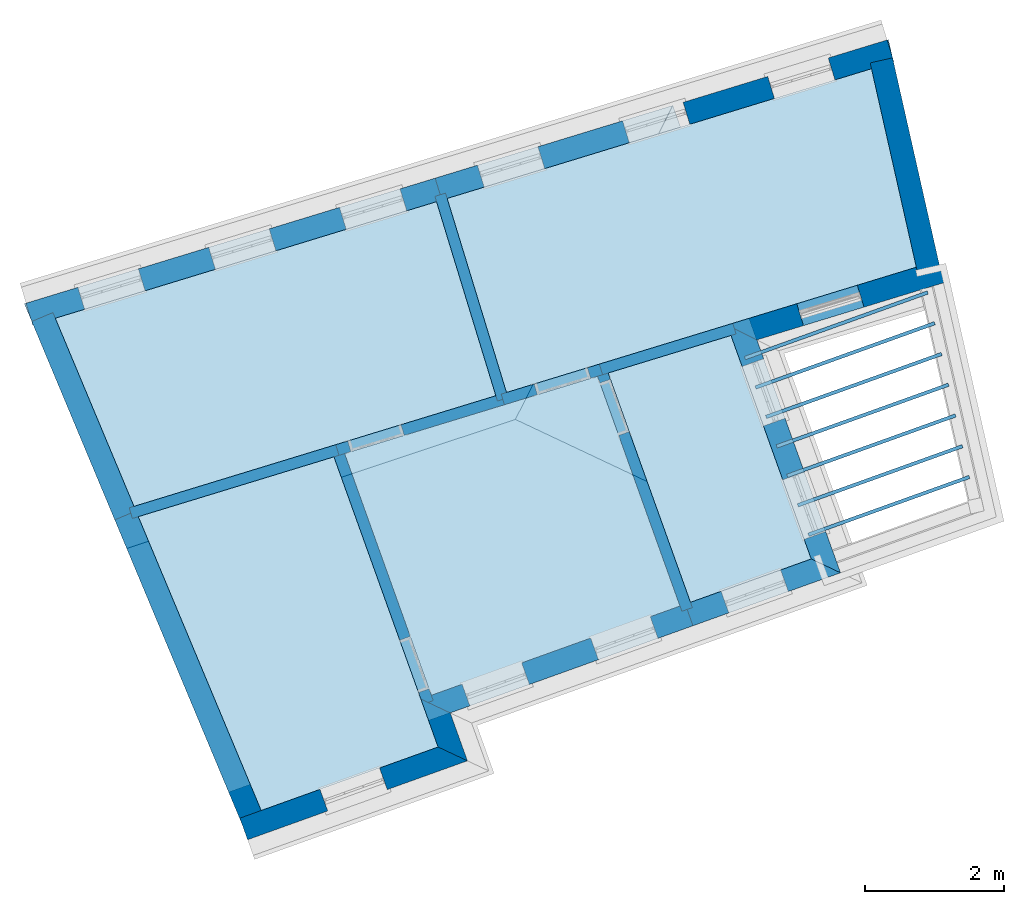
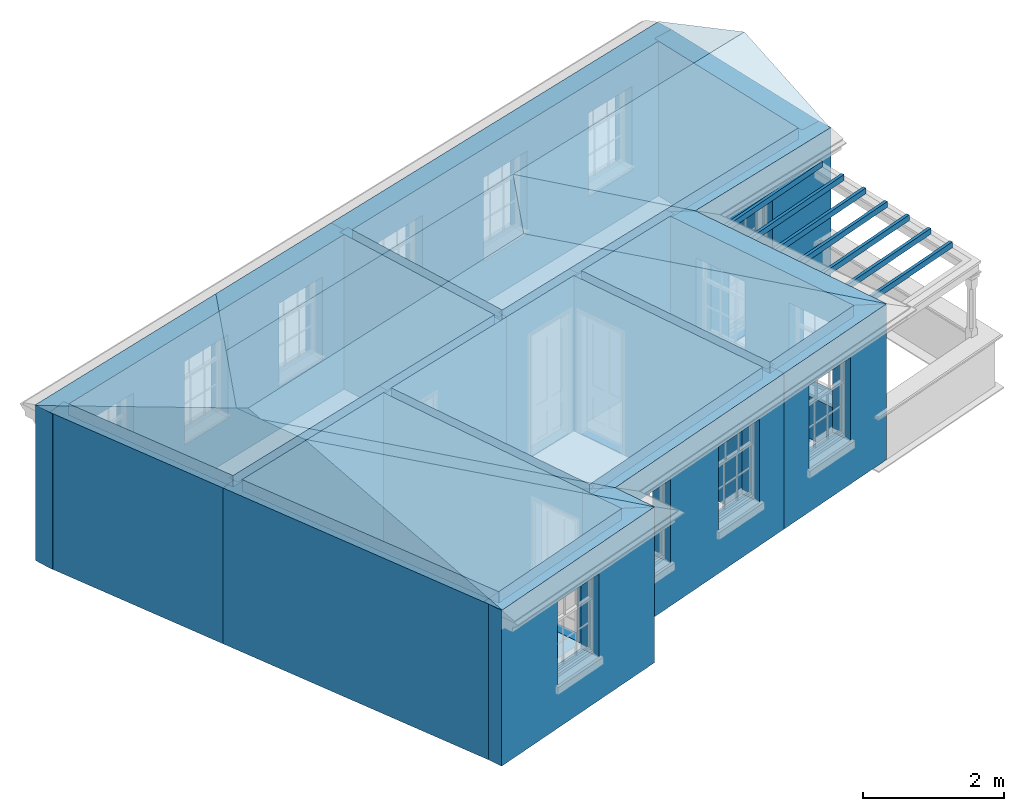
# One storey, part 1 of 10: 18 walls, 16 slabs, 3 roofs, 17 openings.
"""IFC2X3 building model written with IfcOpenShell, lengths in metres."""

import ifcopenshell
import ifcopenshell.guid

model = None  # the IFC model being written
_history = None  # IfcOwnerHistory: only IFC2X3 demands one
_inside = {}  # id of a spatial element -> (the spatial element, [elements in it])
_under = {}  # id of a project, library or spatial element -> (it, [spatial elements below it])
_declared = {}  # id of a project -> (the project, [libraries it declares])
_typed = {}  # id of a type object -> (the type object, [elements of that type])
_made_of = {}  # id of a material, layer set ... -> (it, [elements and type objects made of it])


def new_model(schema):
    """Start an empty IFC model of exactly this schema.

    Asked for "IFC4X3", IfcOpenShell would pick the latest addendum, in which some entities
    have other attributes; the version numbers below select the first issue.
    IFC2X3 requires an IfcOwnerHistory on every rooted entity: one is made here for all.
    """
    global model, _history
    if schema == "IFC4X3":
        model = ifcopenshell.file(schema_version=(4, 3, 0, 0))
    else:
        model = ifcopenshell.file(schema=schema)
    _inside.clear()
    _under.clear()
    _declared.clear()
    _typed.clear()
    _made_of.clear()
    _history = None
    if model.schema == "IFC2X3":
        org = make("IfcOrganization", Name="unknown")
        user = make(
            "IfcPersonAndOrganization",
            ThePerson=make("IfcPerson", FamilyName="unknown"),
            TheOrganization=org,
        )
        app = make(
            "IfcApplication",
            ApplicationDeveloper=org,
            Version="unknown",
            ApplicationFullName="unknown",
            ApplicationIdentifier="unknown",
        )
        _history = make(
            "IfcOwnerHistory",
            OwningUser=user,
            OwningApplication=app,
            ChangeAction="ADDED",
            CreationDate=0,
        )
    return model


def make(cls, **values):
    """One entity of the class cls with the attributes given. An attribute that is None is left unset."""
    return model.create_entity(
        cls, **{name: value for name, value in values.items() if value is not None}
    )


def rooted(cls, **values):
    """An entity with a GlobalId (a new one), such as an element, a storey or a relation."""
    return make(cls, GlobalId=ifcopenshell.guid.new(), OwnerHistory=_history, **values)


def si_unit(unit_type, name, prefix=None):
    """IfcSIUnit, for example si_unit("LENGTHUNIT", "METRE", prefix="MILLI")."""
    return make("IfcSIUnit", UnitType=unit_type, Prefix=prefix, Name=name)


def assignment(units):
    """IfcUnitAssignment: the units of a project."""
    return None if units is None else make("IfcUnitAssignment", Units=units)


def point(xyz):
    """IfcCartesianPoint."""
    return None if xyz is None else make("IfcCartesianPoint", Coordinates=xyz)


def direction(xyz):
    """IfcDirection."""
    return None if xyz is None else make("IfcDirection", DirectionRatios=xyz)


def frame(location, z_axis=None, x_axis=None):
    """IfcAxis2Placement3D, a coordinate frame: its origin and axes. An axis left out is left unset."""
    return make(
        "IfcAxis2Placement3D",
        Location=point(location),
        Axis=direction(z_axis),
        RefDirection=direction(x_axis),
    )


def origin():
    """The frame at (0, 0, 0) with its axes left unset."""
    return frame((0.0, 0.0, 0.0))


def place(relative_to, where):
    """IfcLocalPlacement: puts the frame where relative to a parent placement (None: the world)."""
    return make(
        "IfcLocalPlacement", PlacementRelTo=relative_to, RelativePlacement=where
    )


def context(
    kind, dimensions, precision=None, world=None, true_north=None, identifier=None
):
    """IfcGeometricRepresentationContext, for example the 3D "Model" context."""
    return make(
        "IfcGeometricRepresentationContext",
        ContextIdentifier=identifier,
        ContextType=kind,
        CoordinateSpaceDimension=dimensions,
        Precision=precision,
        WorldCoordinateSystem=world,
        TrueNorth=true_north,
    )


def subcontext(parent, identifier, kind, view, scale=None):
    """IfcGeometricRepresentationSubContext, for example "Body" below "Model"."""
    return make(
        "IfcGeometricRepresentationSubContext",
        ContextIdentifier=identifier,
        ContextType=kind,
        ParentContext=parent,
        TargetScale=scale,
        TargetView=view,
    )


def project(units=None, contexts=None):
    """IfcProject with its units and contexts."""
    return rooted(
        "IfcProject",
        Name="project",
        RepresentationContexts=contexts,
        UnitsInContext=assignment(units),
    )


def spatial(cls, under=None, at=None, **own):
    """A site, building, storey or space (cls), placed at a placement, below another one or the project."""
    s = rooted(cls, ObjectPlacement=at, **own)
    if under is not None:
        _under.setdefault(under.id(), (under, []))[1].append(s)
    return s


def polyline(points):
    """IfcPolyline through the points."""
    return make("IfcPolyline", Points=[point(p) for p in points])


def outline(outer, holes=None, kind="AREA"):
    """IfcArbitraryClosedProfileDef: a profile drawn as a closed curve; with holes, ...WithVoids."""
    if holes is None:
        return make("IfcArbitraryClosedProfileDef", ProfileType=kind, OuterCurve=outer)
    return make(
        "IfcArbitraryProfileDefWithVoids",
        ProfileType=kind,
        OuterCurve=outer,
        InnerCurves=holes,
    )


def extrude(swept, where, along, depth):
    """IfcExtrudedAreaSolid: the profile swept, set in the frame where, extruded along a direction by depth."""
    return make(
        "IfcExtrudedAreaSolid",
        SweptArea=swept,
        Position=where,
        ExtrudedDirection=direction(along),
        Depth=depth,
    )


def faces_of(points, faces, orient=None, outer=None):
    """IfcFace entities. A face is a list of loops; a loop is a list of indices into points, from 0.

    orient and outer hold one flag for each loop. By default every Orientation is true, the
    first loop of a face is its IfcFaceOuterBound and the others are IfcFaceBound.
    """
    made = []
    for i, loops in enumerate(faces):
        bounds = []
        for j, loop in enumerate(loops):
            is_outer = j == 0 if outer is None else outer[i][j]
            bounds.append(
                make(
                    "IfcFaceOuterBound" if is_outer else "IfcFaceBound",
                    Bound=make("IfcPolyLoop", Polygon=[points[k] for k in loop]),
                    Orientation=True if orient is None else orient[i][j],
                )
            )
        made.append(make("IfcFace", Bounds=bounds))
    return made


def faceted_brep(points, faces, orient=None, outer=None, voids=None):
    """IfcFacetedBrep: a solid bounded by flat faces; with voids (closed shells), ...WithVoids."""
    shared = [point(p) for p in points]
    hull = make("IfcClosedShell", CfsFaces=faces_of(shared, faces, orient, outer))
    if voids is None:
        return make("IfcFacetedBrep", Outer=hull)
    return make(
        "IfcFacetedBrepWithVoids",
        Outer=hull,
        Voids=[
            make(cls, CfsFaces=faces_of(shared, fs, o, b)) for cls, fs, o, b in voids
        ],
    )


def shape(context_of_items, identifier, shape_type, items):
    """IfcShapeRepresentation: the items that make up one representation, for example the "Body"."""
    return make(
        "IfcShapeRepresentation",
        ContextOfItems=context_of_items,
        RepresentationIdentifier=identifier,
        RepresentationType=shape_type,
        Items=items,
    )


def material(Name=None, Category=None):
    """IfcMaterial."""
    return make("IfcMaterial", Name=Name, Category=Category)


def layer(
    of_material, thickness, ventilated=None, Name=None, Category=None, Priority=None
):
    """IfcMaterialLayer: one layer of a wall or slab, of a material (None: an air gap)."""
    return make(
        "IfcMaterialLayer",
        Material=of_material,
        LayerThickness=thickness,
        IsVentilated=ventilated,
        Name=Name,
        Category=Category,
        Priority=Priority,
    )


def layer_set(layers, Name=None):
    """IfcMaterialLayerSet."""
    return make("IfcMaterialLayerSet", MaterialLayers=layers, LayerSetName=Name)


def layer_usage(for_layer_set, set_direction, sense, offset, extent=None):
    """IfcMaterialLayerSetUsage: how a layer set lies in its element."""
    return make(
        "IfcMaterialLayerSetUsage",
        ForLayerSet=for_layer_set,
        LayerSetDirection=set_direction,
        DirectionSense=sense,
        OffsetFromReferenceLine=offset,
        ReferenceExtent=extent,
    )


def made_of(thing, what):
    """Note that an element or type object is made of a material, layer set ...; save() writes the relation."""
    if what is not None:
        _made_of.setdefault(what.id(), (what, []))[1].append(thing)
    return thing


def element(
    cls,
    number,
    at=None,
    inside=None,
    cuts=None,
    type_object=None,
    material=None,
    context=None,
    identifier="Body",
    shape_type=None,
    held_by="IfcProductDefinitionShape",
    body=None,
    shapes=None,
    **own,
):
    """One element of the class cls, such as IfcWall. Its Tag is "e" and its number.

    at: its placement. inside: the storey or other place that contains it. cuts: it is an
    opening in that element (IfcRelVoidsElement). A single representation is given by context,
    identifier, shape_type and body (its items); several are given by shapes. held_by: the class
    of the entity that holds the representations. save() writes the other relations.
    """
    e = rooted(cls, Tag="e%d" % number, ObjectPlacement=at, **own)
    if body is not None:
        shapes = [shape(context, identifier, shape_type, body)]
    if shapes is not None:
        e.Representation = make(held_by, Representations=shapes)
    if inside is not None:
        _inside.setdefault(inside.id(), (inside, []))[1].append(e)
    if cuts is not None:
        rooted(
            "IfcRelVoidsElement", RelatingBuildingElement=cuts, RelatedOpeningElement=e
        )
    if type_object is not None:
        _typed.setdefault(type_object.id(), (type_object, []))[1].append(e)
    return made_of(e, material)


def aggregate(whole, parts):
    """IfcRelAggregates: a whole, such as a stair, and the parts it consists of."""
    return rooted("IfcRelAggregates", RelatingObject=whole, RelatedObjects=parts)


def save(model, path):
    """Write the relations noted so far, then the file.

    IfcRelAggregates (storeys below a building ...), IfcRelContainedInSpatialStructure (elements
    in a storey), IfcRelDefinesByType, IfcRelAssociatesMaterial and IfcRelDeclares: one each for
    every whole, place, type object, material and project.
    """
    for whole, parts in _under.values():
        aggregate(whole, parts)
    for where, things in _inside.values():
        rooted(
            "IfcRelContainedInSpatialStructure",
            RelatedElements=things,
            RelatingStructure=where,
        )
    for kind, things in _typed.values():
        rooted("IfcRelDefinesByType", RelatedObjects=things, RelatingType=kind)
    for what, things in _made_of.values():
        rooted("IfcRelAssociatesMaterial", RelatedObjects=things, RelatingMaterial=what)
    for by, libraries in _declared.values():
        rooted("IfcRelDeclares", RelatingContext=by, RelatedDefinitions=libraries)
    model.write(path)


model = new_model("IFC2X3")

# Units and contexts
model_context = context("Model", 3, world=origin())
body_context = subcontext(model_context, "Body", "Model", "MODEL_VIEW")
ifc_project = project(units=[si_unit("PLANEANGLEUNIT", "RADIAN"), si_unit("MASSUNIT", "GRAM", prefix="KILO"), si_unit("FORCEUNIT", "NEWTON", prefix="KILO"), si_unit("LENGTHUNIT", "METRE")], contexts=[model_context])

# Site, building, storey
site_placement = place(None, origin())
site = spatial("IfcSite", under=ifc_project, at=site_placement, CompositionType="ELEMENT")
building_placement = place(None, origin())
building = spatial("IfcBuilding", under=site, at=building_placement, Name="Building plot-9", CompositionType="ELEMENT")
storey_placement = place(None, frame((0.0, 0.0, 4.3)))
storey = spatial("IfcBuildingStorey", under=building, at=storey_placement, Name="Floor 1", CompositionType="ELEMENT", Elevation=4.3)

# Slabs
slab_1_placement = place(storey_placement, frame((0.0, 0.0, 2.5)))
element("IfcSlab", 1, at=slab_1_placement, inside=storey, Name="Slab", ObjectType="Slab", PredefinedType="FLOOR", context=body_context, shape_type="SweptSolid", body=[
    extrude(outline(polyline([(36.3094153316108, 19.1946523649464), (32.6715782779303, 18.0825414666413), (33.9195826432877, 14.605880742874), (37.4958088166108, 15.8896257586881), (36.3094153316108, 19.1946523649464)])), origin(), (0.0, 0.0, 1.0), 0.2),
])
slab_2_placement = place(storey_placement, frame((0.0, 0.0, 2.5)))
element("IfcSlab", 2, at=slab_2_placement, inside=storey, Name="Slab", ObjectType="Slab", PredefinedType="FLOOR", context=body_context, shape_type="SweptSolid", body=[
    extrude(outline(polyline([(38.2290139423755, 19.781486383046), (36.4626012366867, 19.2414823114195), (37.6464003453221, 15.9436830568112), (39.382896856232, 16.5670269486175), (38.2290139423755, 19.781486383046)])), origin(), (0.0, 0.0, 1.0), 0.2),
])
slab_3_placement = place(storey_placement, frame((0.0, 0.0, 2.5)))
element("IfcSlab", 3, at=slab_3_placement, inside=storey, Name="Slab", ObjectType="Slab", PredefinedType="FLOOR", context=body_context, shape_type="SweptSolid", body=[
    extrude(outline(polyline([(29.6423853775052, 17.323806675844), (34.847058744559, 18.9149098198848), (33.9939412709861, 21.7055508982478), (28.5108407742954, 20.0293307353073), (29.6423853775052, 17.323806675844)])), origin(), (0.0, 0.0, 1.0), 0.2),
])
slab_4_placement = place(storey_placement, frame((0.0, 0.0, 2.5)))
element("IfcSlab", 4, at=slab_4_placement, inside=storey, Name="Slab", ObjectType="Slab", PredefinedType="FLOOR", context=body_context, shape_type="SweptSolid", body=[
    extrude(outline(polyline([(32.5183923728544, 18.0357115201682), (29.7044275381413, 17.1754638196932), (31.4719804769569, 12.9492433165192), (34.0163978591737, 13.8626036506437), (32.5183923728544, 18.0357115201682)])), origin(), (0.0, 0.0, 1.0), 0.2),
])
slab_5_placement = place(storey_placement, frame((0.0, 0.0, 2.2)))
element("IfcSlab", 5, at=slab_5_placement, inside=storey, Name="Slab", ObjectType="Slab", PredefinedType="FLOOR", context=body_context, shape_type="SweptSolid", body=[
    extrude(outline(polyline([(38.4221368338657, 19.480275038343), (38.4390297395292, 19.4332151856207), (41.0675551268726, 20.376767467105), (41.0506622212092, 20.4238273198273), (38.4221368338657, 19.480275038343)])), origin(), (0.0, 0.0, 1.0), 0.1),
])
slab_6_placement = place(storey_placement, frame((0.0, 0.0, 2.2)))
element("IfcSlab", 6, at=slab_6_placement, inside=storey, Name="Slab", ObjectType="Slab", PredefinedType="FLOOR", context=body_context, shape_type="SweptSolid", body=[
    extrude(outline(polyline([(38.574172984837, 19.0567363638423), (38.5910658905005, 19.00967651112), (41.1674410007782, 19.934508595667), (41.1505480951147, 19.9815684483893), (38.574172984837, 19.0567363638423)])), origin(), (0.0, 0.0, 1.0), 0.1),
])
slab_7_placement = place(storey_placement, frame((0.0, 0.0, 2.2)))
element("IfcSlab", 7, at=slab_7_placement, inside=storey, Name="Slab", ObjectType="Slab", PredefinedType="FLOOR", context=body_context, shape_type="SweptSolid", body=[
    extrude(outline(polyline([(38.7262091358083, 18.6331976893415), (38.7431020414718, 18.5861378366192), (41.2673268746837, 19.4922497242291), (41.2504339690202, 19.5393095769514), (38.7262091358083, 18.6331976893415)])), origin(), (0.0, 0.0, 1.0), 0.1),
])
slab_8_placement = place(storey_placement, frame((0.0, 0.0, 2.2)))
element("IfcSlab", 8, at=slab_8_placement, inside=storey, Name="Slab", ObjectType="Slab", PredefinedType="FLOOR", context=body_context, shape_type="SweptSolid", body=[
    extrude(outline(polyline([(38.8782452867796, 18.2096590148408), (38.895138192443, 18.1625991621185), (41.3672127485892, 19.0499908527912), (41.3503198429258, 19.0970507055135), (38.8782452867796, 18.2096590148408)])), origin(), (0.0, 0.0, 1.0), 0.1),
])
slab_9_placement = place(storey_placement, frame((0.0, 0.0, 2.2)))
element("IfcSlab", 9, at=slab_9_placement, inside=storey, Name="Slab", ObjectType="Slab", PredefinedType="FLOOR", context=body_context, shape_type="SweptSolid", body=[
    extrude(outline(polyline([(39.0302814377508, 17.7861203403401), (39.0471743434143, 17.7390604876178), (41.4670986224947, 18.6077319813533), (41.4502057168313, 18.6547918340756), (39.0302814377508, 17.7861203403401)])), origin(), (0.0, 0.0, 1.0), 0.1),
])
slab_10_placement = place(storey_placement, frame((0.0, 0.0, 2.2)))
element("IfcSlab", 10, at=slab_10_placement, inside=storey, Name="Slab", ObjectType="Slab", PredefinedType="FLOOR", context=body_context, shape_type="SweptSolid", body=[
    extrude(outline(polyline([(39.1823175887221, 17.3625816658393), (39.1992104943856, 17.315521813117), (41.5669844964003, 18.1654731099154), (41.5500915907368, 18.2125329626377), (39.1823175887221, 17.3625816658393)])), origin(), (0.0, 0.0, 1.0), 0.1),
])
slab_11_placement = place(storey_placement, frame((0.0, 0.0, 2.2)))
element("IfcSlab", 11, at=slab_11_placement, inside=storey, Name="Slab", ObjectType="Slab", PredefinedType="FLOOR", context=body_context, shape_type="SweptSolid", body=[
    extrude(outline(polyline([(39.3343537396934, 16.9390429913386), (39.3512466453569, 16.8919831386163), (41.6668703703058, 17.7232142384775), (41.6499774646423, 17.7702740911998), (39.3343537396934, 16.9390429913386)])), origin(), (0.0, 0.0, 1.0), 0.1),
])
slab_12_placement = place(storey_placement, frame((0.0, 0.0, 2.5)))
element("IfcSlab", 12, at=slab_12_placement, inside=storey, Name="Slab", ObjectType="Slab", PredefinedType="FLOOR", context=body_context, shape_type="SweptSolid", body=[
    extrude(outline(polyline([(40.8949943241668, 20.7638038113086), (40.2503249563729, 23.6181688571686), (34.146951060941, 21.7523270051611), (35.0000685345139, 18.9616859267981), (40.8949943241668, 20.7638038113086)])), origin(), (0.0, 0.0, 1.0), 0.2),
])
slab_13_placement = place(storey_placement, origin())
element("IfcSlab", 13, at=slab_13_placement, inside=storey, Name="Slab", ObjectType="Slab", PredefinedType="FLOOR", context=body_context, shape_type="SweptSolid", body=[
    extrude(outline(polyline([(38.2290139423755, 19.781486383046), (36.4626012366867, 19.2414823114195), (37.6464003453221, 15.9436830568112), (39.382896856232, 16.5670269486175), (38.2290139423755, 19.781486383046)])), origin(), (0.0, 0.0, 1.0), 0.02),
])
slab_14_placement = place(storey_placement, origin())
element("IfcSlab", 14, at=slab_14_placement, inside=storey, Name="Slab", ObjectType="Slab", PredefinedType="FLOOR", context=body_context, shape_type="SweptSolid", body=[
    extrude(outline(polyline([(29.6423853775052, 17.323806675844), (34.847058744559, 18.9149098198848), (33.9939412709861, 21.7055508982478), (28.5108407742954, 20.0293307353073), (29.6423853775052, 17.323806675844)])), origin(), (0.0, 0.0, 1.0), 0.02),
])
slab_15_placement = place(storey_placement, origin())
element("IfcSlab", 15, at=slab_15_placement, inside=storey, Name="Slab", ObjectType="Slab", PredefinedType="FLOOR", context=body_context, shape_type="SweptSolid", body=[
    extrude(outline(polyline([(32.5183923728544, 18.0357115201682), (29.7044275381413, 17.1754638196932), (31.4719804769569, 12.9492433165192), (34.0163978591737, 13.8626036506437), (32.5183923728544, 18.0357115201682)])), origin(), (0.0, 0.0, 1.0), 0.02),
])
slab_16_placement = place(storey_placement, origin())
element("IfcSlab", 16, at=slab_16_placement, inside=storey, Name="Slab", ObjectType="Slab", PredefinedType="FLOOR", context=body_context, shape_type="SweptSolid", body=[
    extrude(outline(polyline([(40.8949943241668, 20.7638038113086), (40.2503249563729, 23.6181688571686), (34.146951060941, 21.7523270051611), (35.0000685345139, 18.9616859267981), (40.8949943241668, 20.7638038113086)])), origin(), (0.0, 0.0, 1.0), 0.02),
])

# Wall, openings
ifc_material_1 = material(Name="Masonry")
ifc_layer_1 = layer(ifc_material_1, 0.33, ventilated=False)
ifc_layer_set_1 = layer_set([ifc_layer_1], Name="My Wall")
ifc_layer_usage_1 = layer_usage(ifc_layer_set_1, "AXIS2", "NEGATIVE", 0.08)
wall_1_placement = place(storey_placement, origin())
wall_1 = element("IfcWallStandardCase", 17, at=wall_1_placement, inside=storey, material=ifc_layer_usage_1, Name="exterior", context=body_context, shape_type="SweptSolid", body=[
    extrude(outline(polyline([(40.5718353424252, 23.7164567131035), (40.4753596219165, 24.0320394048854), (33.9739704454548, 22.0445216434864), (34.0704461659636, 21.7289389517045), (40.5718353424252, 23.7164567131035)])), origin(), (0.0, 0.0, 1.0), 2.7),
])
opening_1_placement = place(storey_placement, frame((0.0, 0.0, 0.75)))
element("IfcOpeningElement", 18, at=opening_1_placement, cuts=wall_1, Name="Opening", ObjectType="Opening", context=body_context, shape_type="SweptSolid", body=[
    extrude(outline(polyline([(39.62768485202, 23.772899609477), (38.7574416716517, 23.5068605014075), (38.8539173921604, 23.1912778096256), (39.7241605725287, 23.457316917695), (39.62768485202, 23.772899609477)])), origin(), (0.0, 0.0, 1.0), 1.445),
])
opening_2_placement = place(storey_placement, frame((0.0, 0.0, 0.75)))
element("IfcOpeningElement", 19, at=opening_2_placement, cuts=wall_1, Name="Opening", ObjectType="Opening", context=body_context, shape_type="SweptSolid", body=[
    extrude(outline(polyline([(37.5402477254676, 23.1347562446946), (36.6700045450993, 22.8687171366251), (36.766480265608, 22.5531344448432), (37.6367234459763, 22.8191735529127), (37.5402477254676, 23.1347562446946)])), origin(), (0.0, 0.0, 1.0), 1.445),
])
opening_3_placement = place(storey_placement, frame((0.0, 0.0, 0.75)))
element("IfcOpeningElement", 20, at=opening_3_placement, cuts=wall_1, Name="Opening", ObjectType="Opening", context=body_context, shape_type="SweptSolid", body=[
    extrude(outline(polyline([(35.4528105989152, 22.4966128799123), (34.5825674185469, 22.2305737718428), (34.6790431390556, 21.9149910800609), (35.5492863194239, 22.1810301881304), (35.4528105989152, 22.4966128799123)])), origin(), (0.0, 0.0, 1.0), 1.445),
])

wall_2_placement = place(storey_placement, origin())
wall_2 = element("IfcWallStandardCase", 21, at=wall_2_placement, inside=storey, material=ifc_layer_usage_1, Name="exterior", context=body_context, shape_type="SweptSolid", body=[
    extrude(outline(polyline([(34.0704461659636, 21.7289389517045), (33.9739704454548, 22.0445216434864), (28.0907694978616, 20.2459881209039), (28.1872452183703, 19.930405429122), (34.0704461659636, 21.7289389517045)])), origin(), (0.0, 0.0, 1.0), 2.7),
])
opening_4_placement = place(storey_placement, frame((0.0, 0.0, 0.75)))
element("IfcOpeningElement", 22, at=opening_4_placement, cuts=wall_2, Name="Opening", ObjectType="Opening", context=body_context, shape_type="SweptSolid", body=[
    extrude(outline(polyline([(33.4684048438409, 21.8899668882661), (32.5981616634725, 21.6239277801966), (32.6946373839813, 21.3083450884147), (33.5648805643496, 21.5743841964841), (33.4684048438409, 21.8899668882661)])), origin(), (0.0, 0.0, 1.0), 1.445),
])
opening_5_placement = place(storey_placement, frame((0.0, 0.0, 0.75)))
element("IfcOpeningElement", 23, at=opening_5_placement, cuts=wall_2, Name="Opening", ObjectType="Opening", context=body_context, shape_type="SweptSolid", body=[
    extrude(outline(polyline([(31.5870304602446, 21.3148182697559), (30.7167872798763, 21.0487791616865), (30.813263000385, 20.7331964699045), (31.6835061807533, 20.999235577974), (31.5870304602446, 21.3148182697559)])), origin(), (0.0, 0.0, 1.0), 1.445),
])
opening_6_placement = place(storey_placement, frame((0.0, 0.0, 0.75)))
element("IfcOpeningElement", 24, at=opening_6_placement, cuts=wall_2, Name="Opening", ObjectType="Opening", context=body_context, shape_type="SweptSolid", body=[
    extrude(outline(polyline([(29.7056560766483, 20.7396696512458), (28.83541289628, 20.4736305431763), (28.9318886167887, 20.1580478513944), (29.8021317971571, 20.4240869594639), (29.7056560766483, 20.7396696512458)])), origin(), (0.0, 0.0, 1.0), 1.445),
])

# Wall, opening
wall_3_placement = place(storey_placement, origin())
wall_3 = element("IfcWallStandardCase", 25, at=wall_3_placement, inside=storey, material=ifc_layer_usage_1, Name="exterior", context=body_context, shape_type="SweptSolid", body=[
    extrude(outline(polyline([(31.1651656744123, 12.8391071130311), (31.2766588517913, 12.5285120850639), (34.4384860645198, 13.6635018000555), (34.0163978591737, 13.8626036506437), (31.1651656744123, 12.8391071130311)])), origin(), (0.0, 0.0, 1.0), 2.7),
])
opening_7_placement = place(storey_placement, frame((0.0, 0.0, 0.75)))
element("IfcOpeningElement", 26, at=opening_7_placement, cuts=wall_3, Name="Opening", ObjectType="Opening", context=body_context, shape_type="SweptSolid", body=[
    extrude(outline(polyline([(32.4293277983826, 12.9422815010221), (33.2858171179285, 13.2497323840973), (33.1743239405496, 13.5603274120645), (32.3178346210036, 13.2528765289893), (32.4293277983826, 12.9422815010221)])), origin(), (0.0, 0.0, 1.0), 1.445),
])

# Wall
wall_4_placement = place(storey_placement, origin())
element("IfcWallStandardCase", 27, at=wall_4_placement, inside=storey, material=ifc_layer_usage_1, Name="exterior", context=body_context, shape_type="SweptSolid", body=[
    extrude(outline(polyline([(34.0163978591737, 13.8626036506437), (34.4384860645198, 13.6635018000555), (34.1910793199225, 14.3527215941627), (33.7689911145764, 14.5518234447509), (34.0163978591737, 13.8626036506437)])), origin(), (0.0, 0.0, 1.0), 2.7),
])

# Wall, openings
wall_5_placement = place(storey_placement, origin())
wall_5 = element("IfcWallStandardCase", 28, at=wall_5_placement, inside=storey, material=ifc_layer_usage_1, Name="exterior", context=body_context, shape_type="SweptSolid", body=[
    extrude(outline(polyline([(33.7689911145764, 14.5518234447509), (34.1910793199225, 14.3527215941627), (37.6825977583454, 15.6060593797825), (37.5711045809664, 15.9166544077497), (33.7689911145764, 14.5518234447509)])), origin(), (0.0, 0.0, 1.0), 2.7),
])
opening_8_placement = place(storey_placement, frame((0.0, 0.0, 0.75)))
element("IfcOpeningElement", 29, at=opening_8_placement, cuts=wall_5, Name="Opening", ObjectType="Opening", context=body_context, shape_type="SweptSolid", body=[
    extrude(outline(polyline([(34.4734384362563, 14.4540790281435), (35.3299277558022, 14.7615299112188), (35.2184345784233, 15.072124939186), (34.3619452588774, 14.7646740561107), (34.4734384362563, 14.4540790281435)])), origin(), (0.0, 0.0, 1.0), 1.445),
])
opening_9_placement = place(storey_placement, frame((0.0, 0.0, 0.75)))
element("IfcOpeningElement", 30, at=opening_9_placement, cuts=wall_5, Name="Opening", ObjectType="Opening", context=body_context, shape_type="SweptSolid", body=[
    extrude(outline(polyline([(36.3226486730638, 15.1178833597605), (37.1791379926097, 15.4253342428358), (37.0676448152308, 15.735929270803), (36.2111554956849, 15.4284783877277), (36.3226486730638, 15.1178833597605)])), origin(), (0.0, 0.0, 1.0), 1.445),
])

# Wall, opening
wall_6_placement = place(storey_placement, origin())
wall_6 = element("IfcWallStandardCase", 31, at=wall_6_placement, inside=storey, material=ifc_layer_usage_1, Name="exterior", context=body_context, shape_type="SweptSolid", body=[
    extrude(outline(polyline([(37.5711045809664, 15.9166544077497), (37.6825977583454, 15.6060593797825), (39.8049850615781, 16.3679250980293), (39.382896856232, 16.5670269486175), (37.5711045809664, 15.9166544077497)])), origin(), (0.0, 0.0, 1.0), 2.7),
])
opening_10_placement = place(storey_placement, frame((0.0, 0.0, 0.75)))
element("IfcOpeningElement", 32, at=opening_10_placement, cuts=wall_6, Name="Opening", ObjectType="Opening", context=body_context, shape_type="SweptSolid", body=[
    extrude(outline(polyline([(38.197897118383, 15.7910345332096), (39.0543864379289, 16.0984854162848), (38.94289326055, 16.409080444252), (38.0864039410041, 16.1016295611768), (38.197897118383, 15.7910345332096)])), origin(), (0.0, 0.0, 1.0), 1.445),
])

# Wall, openings
wall_7_placement = place(storey_placement, origin())
wall_7 = element("IfcWallStandardCase", 33, at=wall_7_placement, inside=storey, material=ifc_layer_usage_1, Name="exterior", context=body_context, shape_type="SweptSolid", body=[
    extrude(outline(polyline([(39.382896856232, 16.5670269486175), (39.8049850615781, 16.3679250980293), (38.6024618598675, 19.7178854834714), (38.174894424001, 19.9322512434462), (39.382896856232, 16.5670269486175)])), origin(), (0.0, 0.0, 1.0), 2.7),
])
opening_11_placement = place(storey_placement, frame((0.0, 0.0, 0.75)))
element("IfcOpeningElement", 34, at=opening_11_placement, cuts=wall_7, Name="Opening", ObjectType="Opening", context=body_context, shape_type="SweptSolid", body=[
    extrude(outline(polyline([(39.5921344502183, 16.9608792423303), (39.2846835671431, 17.8173685618762), (38.9740885391759, 17.7058753844973), (39.2815394222511, 16.8493860649514), (39.5921344502183, 16.9608792423303)])), origin(), (0.0, 0.0, 1.0), 1.445),
])
opening_12_placement = place(storey_placement, frame((0.0, 0.0, 0.75)))
element("IfcOpeningElement", 35, at=opening_12_placement, cuts=wall_7, Name="Opening", ObjectType="Opening", context=body_context, shape_type="SweptSolid", body=[
    extrude(outline(polyline([(39.0071192447112, 18.5906006153087), (38.6996683616359, 19.4470899348546), (38.3890733336687, 19.3355967574757), (38.696524216744, 18.4791074379298), (39.0071192447112, 18.5906006153087)])), origin(), (0.0, 0.0, 1.0), 1.445),
])

# Wall, opening
wall_8_placement = place(storey_placement, origin())
wall_8 = element("IfcWallStandardCase", 36, at=wall_8_placement, inside=storey, material=ifc_layer_usage_1, Name="exterior", context=body_context, shape_type="SweptSolid", body=[
    extrude(outline(polyline([(38.174894424001, 19.9322512434462), (38.6024618598675, 19.7178854834714), (41.3015513002929, 20.5430150145373), (41.2050755797842, 20.8585977063192), (38.174894424001, 19.9322512434462)])), origin(), (0.0, 0.0, 1.0), 2.7),
])
opening_13_placement = place(storey_placement, frame((0.0, 0.0, 0.0199999999999996)))
element("IfcOpeningElement", 37, at=opening_13_placement, cuts=wall_8, Name="Opening", ObjectType="Opening", context=body_context, shape_type="SweptSolid", body=[
    extrude(outline(polyline([(39.2719325629492, 19.9225471145469), (40.1421757433175, 20.1885862226164), (40.0457000228088, 20.5041689143983), (39.1754568424405, 20.2381298063288), (39.2719325629492, 19.9225471145469)])), origin(), (0.0, 0.0, 1.0), 2.08),
])

# Walls
wall_9_placement = place(storey_placement, origin())
element("IfcWallStandardCase", 38, at=wall_9_placement, inside=storey, material=ifc_layer_usage_1, Name="party", context=body_context, shape_type="SweptSolid", body=[
    extrude(outline(polyline([(40.9113513512166, 20.6913807544711), (41.2332436027483, 20.7640813624728), (40.553227258476, 23.774950159212), (40.2313350069443, 23.7022495512103), (40.9113513512166, 20.6913807544711)])), origin(), (0.0, 0.0, 1.0), 2.7),
])
wall_10_placement = place(storey_placement, origin())
element("IfcWallStandardCase", 39, at=wall_10_placement, inside=storey, material=ifc_layer_usage_1, Name="party", context=body_context, shape_type="SweptSolid", body=[
    extrude(outline(polyline([(28.4767399571768, 20.1108658165582), (28.1722943509096, 19.9835360367555), (29.3658811147555, 17.1296691211414), (29.6703267210227, 17.2569989009441), (28.4767399571768, 20.1108658165582)])), origin(), (0.0, 0.0, 1.0), 2.7),
])
wall_11_placement = place(storey_placement, origin())
element("IfcWallStandardCase", 40, at=wall_11_placement, inside=storey, material=ifc_layer_usage_1, Name="party", context=body_context, shape_type="SweptSolid", body=[
    extrude(outline(polyline([(29.6703267210227, 17.2569989009441), (29.3658811147555, 17.1296691211414), (31.1968529762769, 12.7518139225968), (31.5012985825441, 12.8791437023995), (29.6703267210227, 17.2569989009441)])), origin(), (0.0, 0.0, 1.0), 2.7),
])
ifc_material_2 = material(Name="Masonry")
ifc_layer_2 = layer(ifc_material_2, 0.16, ventilated=False)
ifc_layer_set_2 = layer_set([ifc_layer_2], Name="My Wall")
ifc_layer_usage_2 = layer_usage(ifc_layer_set_2, "AXIS2", "NEGATIVE", 0.08)
wall_12_placement = place(storey_placement, origin())
element("IfcWallStandardCase", 41, at=wall_12_placement, inside=storey, material=ifc_layer_usage_2, Name="interior", context=body_context, shape_type="SweptSolid", body=[
    extrude(outline(polyline([(36.3355604715048, 19.3699546633605), (36.3823365784182, 19.2169448734057), (38.3019351891829, 19.8037788915052), (38.2551590822695, 19.95678868146), (36.3355604715048, 19.3699546633605)])), origin(), (0.0, 0.0, 1.0), 2.7),
])
wall_13_placement = place(storey_placement, origin())
element("IfcWallStandardCase", 42, at=wall_13_placement, inside=storey, material=ifc_layer_usage_2, Name="interior", context=body_context, shape_type="SweptSolid", body=[
    extrude(outline(polyline([(32.5913136196618, 18.0580040286275), (32.5445375127484, 18.2110138185823), (29.5731336721073, 17.3026359705148), (29.6199097790207, 17.14962618056), (32.5913136196618, 18.0580040286275)])), origin(), (0.0, 0.0, 1.0), 2.7),
])

# Wall, opening
wall_14_placement = place(storey_placement, origin())
wall_14 = element("IfcWallStandardCase", 43, at=wall_14_placement, inside=storey, material=ifc_layer_usage_2, Name="interior", context=body_context, shape_type="SweptSolid", body=[
    extrude(outline(polyline([(36.3823365784182, 19.2169448734057), (36.3355604715048, 19.3699546633605), (34.9235636395364, 18.9382978733414), (34.9703397464498, 18.7852880833866), (36.3823365784182, 19.2169448734057)])), origin(), (0.0, 0.0, 1.0), 2.7),
])
opening_14_placement = place(storey_placement, frame((0.0, 0.0, 0.0199999999999996)))
element("IfcOpeningElement", 44, at=opening_14_placement, cuts=wall_14, Name="Opening", ObjectType="Opening", context=body_context, shape_type="SweptSolid", body=[
    extrude(outline(polyline([(36.1634244578056, 19.3173315430831), (35.3983755080313, 19.0834510085165), (35.4451516149446, 18.9304412185616), (36.2102005647189, 19.1643217531282), (36.1634244578056, 19.3173315430831)])), origin(), (0.0, 0.0, 1.0), 2.1),
])

wall_15_placement = place(storey_placement, origin())
wall_15 = element("IfcWallStandardCase", 45, at=wall_15_placement, inside=storey, material=ifc_layer_usage_2, Name="interior", context=body_context, shape_type="SweptSolid", body=[
    extrude(outline(polyline([(32.6432213305608, 18.1615375726665), (32.4926298018494, 18.1074802745433), (33.7960197636379, 14.4765276803952), (33.9466112923493, 14.5305849785184), (32.6432213305608, 18.1615375726665)])), origin(), (0.0, 0.0, 1.0), 2.7),
])
opening_15_placement = place(storey_placement, frame((0.0, 0.0, 0.0199999999999996)))
element("IfcOpeningElement", 46, at=opening_15_placement, cuts=wall_15, Name="Opening", ObjectType="Opening", context=body_context, shape_type="SweptSolid", body=[
    extrude(outline(polyline([(33.4649188126338, 15.3989007937524), (33.7352053032494, 14.6459431501955), (33.8857968319608, 14.7000004483187), (33.6155103413452, 15.4529580918755), (33.4649188126338, 15.3989007937524)])), origin(), (0.0, 0.0, 1.0), 2.1),
])

wall_16_placement = place(storey_placement, origin())
wall_16 = element("IfcWallStandardCase", 47, at=wall_16_placement, inside=storey, material=ifc_layer_usage_2, Name="interior", context=body_context, shape_type="SweptSolid", body=[
    extrude(outline(polyline([(36.4342442893172, 19.3204784174447), (36.2836527606058, 19.2664211193215), (37.5228374656723, 15.8143299943324), (37.6734289943837, 15.8683872924556), (36.4342442893172, 19.3204784174447)])), origin(), (0.0, 0.0, 1.0), 2.7),
])
opening_16_placement = place(storey_placement, frame((0.0, 0.0, 0.0199999999999996)))
element("IfcOpeningElement", 48, at=opening_16_placement, cuts=wall_16, Name="Opening", ObjectType="Opening", context=body_context, shape_type="SweptSolid", body=[
    extrude(outline(polyline([(36.3444672209943, 19.0970056495212), (36.6147537116099, 18.3440480059644), (36.7653452403213, 18.3981053040875), (36.4950587497057, 19.1510629476444), (36.3444672209943, 19.0970056495212)])), origin(), (0.0, 0.0, 1.0), 2.1),
])

# Wall
wall_17_placement = place(storey_placement, origin())
element("IfcWallStandardCase", 49, at=wall_17_placement, inside=storey, material=ifc_layer_usage_2, Name="interior", context=body_context, shape_type="SweptSolid", body=[
    extrude(outline(polyline([(34.8704467980157, 18.8384049249073), (35.0234565879705, 18.8851810318207), (34.1235630074843, 21.8288319001386), (33.9705532175295, 21.7820557932252), (34.8704467980157, 18.8384049249073)])), origin(), (0.0, 0.0, 1.0), 2.7),
])

# Wall, opening
wall_18_placement = place(storey_placement, origin())
wall_18 = element("IfcWallStandardCase", 50, at=wall_18_placement, inside=storey, material=ifc_layer_usage_2, Name="interior", context=body_context, shape_type="SweptSolid", body=[
    extrude(outline(polyline([(34.9703397464498, 18.7852880833866), (34.9235636395364, 18.9382978733414), (32.5445375127484, 18.2110138185823), (32.5913136196618, 18.0580040286275), (34.9703397464498, 18.7852880833866)])), origin(), (0.0, 0.0, 1.0), 2.7),
])
opening_17_placement = place(storey_placement, frame((0.0, 0.0, 0.0199999999999996)))
element("IfcOpeningElement", 51, at=opening_17_placement, cuts=wall_18, Name="Opening", ObjectType="Opening", context=body_context, shape_type="SweptSolid", body=[
    extrude(outline(polyline([(33.481722476222, 18.4975174734264), (32.7166735264477, 18.2636369388598), (32.763449633361, 18.1106271489049), (33.5284985831353, 18.3445076834715), (33.481722476222, 18.4975174734264)])), origin(), (0.0, 0.0, 1.0), 2.1),
])

# Roofs
roof_1_placement = place(building_placement, origin())
element("IfcRoof", 52, at=roof_1_placement, inside=storey, Name="Roof", ShapeType="FREEFORM", context=body_context, shape_type="Brep", held_by="IfcProductRepresentation", body=[
    faceted_brep([(37.39217, 23.089488, 7.0), (28.065729, 20.238333, 7.0), (29.538304, 16.717405, 8.573022), (35.128262, 18.573967, 8.514526), (31.005548, 13.209223, 7.0), (39.804985, 16.367925, 7.0)], [[[0, 1, 2, 3]], [[4, 5, 3, 2]], [[5, 4, 1, 0]], [[5, 0, 3]], [[1, 4, 2]]]),
])
roof_2_placement = place(building_placement, origin())
element("IfcRoof", 53, at=roof_2_placement, inside=storey, Name="Roof", ShapeType="FREEFORM", context=body_context, shape_type="Brep", held_by="IfcProductRepresentation", body=[
    faceted_brep([(29.453198, 16.920895, 7.0), (41.284359, 20.537759, 7.0), (40.889121, 22.287731, 7.741055), (28.759464, 18.579614, 7.741055), (40.493884, 24.037702, 7.0), (28.065729, 20.238333, 7.0)], [[[0, 1, 2, 3]], [[4, 5, 3, 2]], [[5, 4, 1, 0]], [[5, 0, 3]], [[1, 4, 2]]]),
])
roof_3_placement = place(building_placement, origin())
element("IfcRoof", 54, at=roof_3_placement, inside=storey, Name="Roof", ShapeType="FREEFORM", context=body_context, shape_type="Brep", held_by="IfcProductRepresentation", body=[
    faceted_brep([(34.438486, 13.663502, 7.0), (31.681548, 21.343713, 7.0), (29.458165, 16.909019, 8.487416), (29.925142, 15.792477, 8.461617), (31.288472, 12.532753, 7.0), (28.065729, 20.238333, 7.0)], [[[0, 1, 2, 3]], [[4, 5, 1, 0]], [[3, 4, 0]], [[2, 1, 5]], [[2, 5, 4, 3]]]),
])

save(model, "model.ifc")
